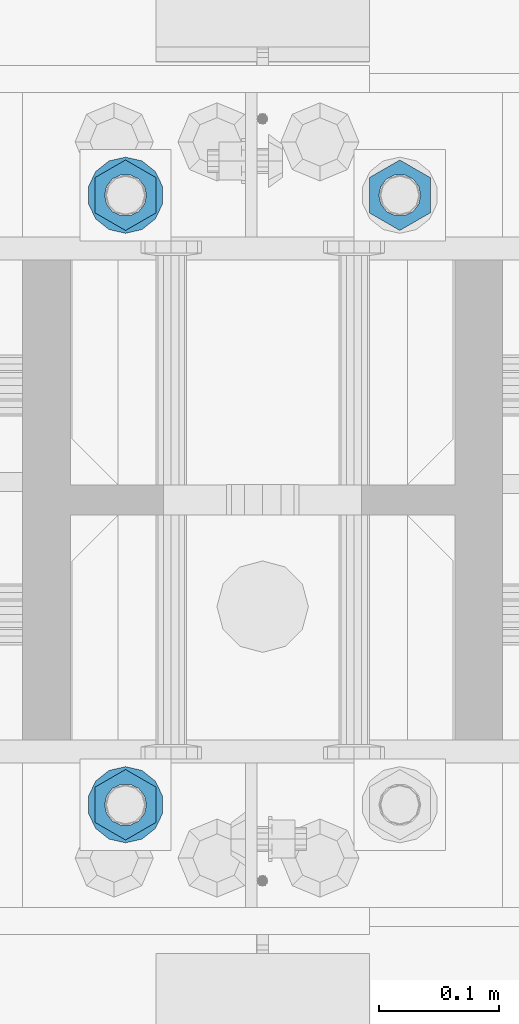
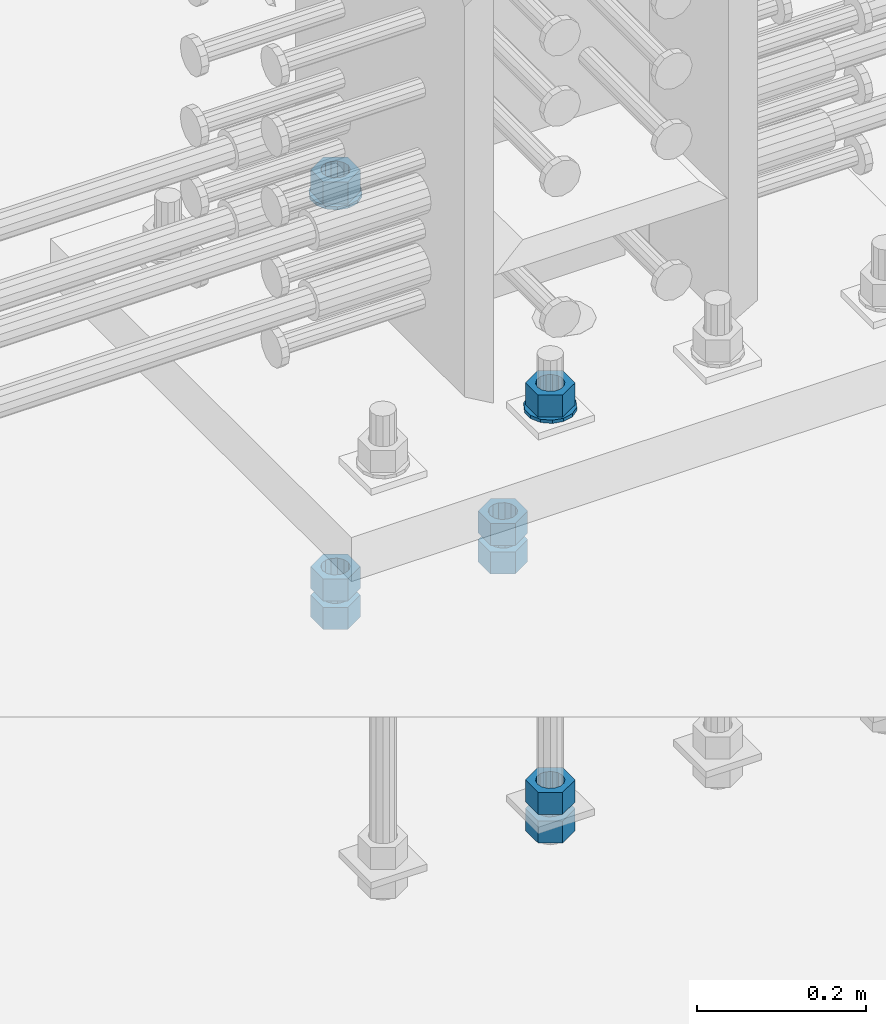
# One storey, part 1005 of 1763: 10 columns, 1 element without a shape of its own.
"""IFC2X3 building model written with IfcOpenShell, lengths in millimetres."""

import ifcopenshell
import ifcopenshell.guid

model = None  # the IFC model being written
_history = None  # IfcOwnerHistory: only IFC2X3 demands one
_inside = {}  # id of a spatial element -> (the spatial element, [elements in it])
_under = {}  # id of a project, library or spatial element -> (it, [spatial elements below it])
_declared = {}  # id of a project -> (the project, [libraries it declares])
_typed = {}  # id of a type object -> (the type object, [elements of that type])
_made_of = {}  # id of a material, layer set ... -> (it, [elements and type objects made of it])


def new_model(schema):
    """Start an empty IFC model of exactly this schema.

    Asked for "IFC4X3", IfcOpenShell would pick the latest addendum, in which some entities
    have other attributes; the version numbers below select the first issue.
    IFC2X3 requires an IfcOwnerHistory on every rooted entity: one is made here for all.
    """
    global model, _history
    if schema == "IFC4X3":
        model = ifcopenshell.file(schema_version=(4, 3, 0, 0))
    else:
        model = ifcopenshell.file(schema=schema)
    _inside.clear()
    _under.clear()
    _declared.clear()
    _typed.clear()
    _made_of.clear()
    _history = None
    if model.schema == "IFC2X3":
        org = make("IfcOrganization", Name="unknown")
        user = make(
            "IfcPersonAndOrganization",
            ThePerson=make("IfcPerson", FamilyName="unknown"),
            TheOrganization=org,
        )
        app = make(
            "IfcApplication",
            ApplicationDeveloper=org,
            Version="unknown",
            ApplicationFullName="unknown",
            ApplicationIdentifier="unknown",
        )
        _history = make(
            "IfcOwnerHistory",
            OwningUser=user,
            OwningApplication=app,
            ChangeAction="ADDED",
            CreationDate=0,
        )
    return model


def make(cls, **values):
    """One entity of the class cls with the attributes given. An attribute that is None is left unset."""
    return model.create_entity(
        cls, **{name: value for name, value in values.items() if value is not None}
    )


def rooted(cls, **values):
    """An entity with a GlobalId (a new one), such as an element, a storey or a relation."""
    return make(cls, GlobalId=ifcopenshell.guid.new(), OwnerHistory=_history, **values)


def si_unit(unit_type, name, prefix=None):
    """IfcSIUnit, for example si_unit("LENGTHUNIT", "METRE", prefix="MILLI")."""
    return make("IfcSIUnit", UnitType=unit_type, Prefix=prefix, Name=name)


def assignment(units):
    """IfcUnitAssignment: the units of a project."""
    return None if units is None else make("IfcUnitAssignment", Units=units)


def point(xyz):
    """IfcCartesianPoint."""
    return None if xyz is None else make("IfcCartesianPoint", Coordinates=xyz)


def direction(xyz):
    """IfcDirection."""
    return None if xyz is None else make("IfcDirection", DirectionRatios=xyz)


def frame(location, z_axis=None, x_axis=None):
    """IfcAxis2Placement3D, a coordinate frame: its origin and axes. An axis left out is left unset."""
    return make(
        "IfcAxis2Placement3D",
        Location=point(location),
        Axis=direction(z_axis),
        RefDirection=direction(x_axis),
    )


def origin_with_axes():
    """The frame at (0, 0, 0) with the z axis (0, 0, 1) and the x axis (1, 0, 0) written out."""
    return frame((0.0, 0.0, 0.0), z_axis=(0.0, 0.0, 1.0), x_axis=(1.0, 0.0, 0.0))


def place(relative_to, where):
    """IfcLocalPlacement: puts the frame where relative to a parent placement (None: the world)."""
    return make(
        "IfcLocalPlacement", PlacementRelTo=relative_to, RelativePlacement=where
    )


def context(
    kind, dimensions, precision=None, world=None, true_north=None, identifier=None
):
    """IfcGeometricRepresentationContext, for example the 3D "Model" context."""
    return make(
        "IfcGeometricRepresentationContext",
        ContextIdentifier=identifier,
        ContextType=kind,
        CoordinateSpaceDimension=dimensions,
        Precision=precision,
        WorldCoordinateSystem=world,
        TrueNorth=true_north,
    )


def subcontext(parent, identifier, kind, view, scale=None):
    """IfcGeometricRepresentationSubContext, for example "Body" below "Model"."""
    return make(
        "IfcGeometricRepresentationSubContext",
        ContextIdentifier=identifier,
        ContextType=kind,
        ParentContext=parent,
        TargetScale=scale,
        TargetView=view,
    )


def project(units=None, contexts=None):
    """IfcProject with its units and contexts."""
    return rooted(
        "IfcProject",
        Name="project",
        RepresentationContexts=contexts,
        UnitsInContext=assignment(units),
    )


def spatial(cls, under=None, at=None, **own):
    """A site, building, storey or space (cls), placed at a placement, below another one or the project."""
    s = rooted(cls, ObjectPlacement=at, **own)
    if under is not None:
        _under.setdefault(under.id(), (under, []))[1].append(s)
    return s


def faces_of(points, faces, orient=None, outer=None):
    """IfcFace entities. A face is a list of loops; a loop is a list of indices into points, from 0.

    orient and outer hold one flag for each loop. By default every Orientation is true, the
    first loop of a face is its IfcFaceOuterBound and the others are IfcFaceBound.
    """
    made = []
    for i, loops in enumerate(faces):
        bounds = []
        for j, loop in enumerate(loops):
            is_outer = j == 0 if outer is None else outer[i][j]
            bounds.append(
                make(
                    "IfcFaceOuterBound" if is_outer else "IfcFaceBound",
                    Bound=make("IfcPolyLoop", Polygon=[points[k] for k in loop]),
                    Orientation=True if orient is None else orient[i][j],
                )
            )
        made.append(make("IfcFace", Bounds=bounds))
    return made


def faceted_brep(points, faces, orient=None, outer=None, voids=None):
    """IfcFacetedBrep: a solid bounded by flat faces; with voids (closed shells), ...WithVoids."""
    shared = [point(p) for p in points]
    hull = make("IfcClosedShell", CfsFaces=faces_of(shared, faces, orient, outer))
    if voids is None:
        return make("IfcFacetedBrep", Outer=hull)
    return make(
        "IfcFacetedBrepWithVoids",
        Outer=hull,
        Voids=[
            make(cls, CfsFaces=faces_of(shared, fs, o, b)) for cls, fs, o, b in voids
        ],
    )


def shape(context_of_items, identifier, shape_type, items):
    """IfcShapeRepresentation: the items that make up one representation, for example the "Body"."""
    return make(
        "IfcShapeRepresentation",
        ContextOfItems=context_of_items,
        RepresentationIdentifier=identifier,
        RepresentationType=shape_type,
        Items=items,
    )


def material(Name=None, Category=None):
    """IfcMaterial."""
    return make("IfcMaterial", Name=Name, Category=Category)


def made_of(thing, what):
    """Note that an element or type object is made of a material, layer set ...; save() writes the relation."""
    if what is not None:
        _made_of.setdefault(what.id(), (what, []))[1].append(thing)
    return thing


def type_object(cls, material=None, **own):
    """A type object (cls), such as IfcWallType, which elements share."""
    return made_of(rooted(cls, **own), material)


def element(
    cls,
    number,
    at=None,
    inside=None,
    cuts=None,
    type_object=None,
    material=None,
    context=None,
    identifier="Body",
    shape_type=None,
    held_by="IfcProductDefinitionShape",
    body=None,
    shapes=None,
    **own,
):
    """One element of the class cls, such as IfcWall. Its Tag is "e" and its number.

    at: its placement. inside: the storey or other place that contains it. cuts: it is an
    opening in that element (IfcRelVoidsElement). A single representation is given by context,
    identifier, shape_type and body (its items); several are given by shapes. held_by: the class
    of the entity that holds the representations. save() writes the other relations.
    """
    e = rooted(cls, Tag="e%d" % number, ObjectPlacement=at, **own)
    if body is not None:
        shapes = [shape(context, identifier, shape_type, body)]
    if shapes is not None:
        e.Representation = make(held_by, Representations=shapes)
    if inside is not None:
        _inside.setdefault(inside.id(), (inside, []))[1].append(e)
    if cuts is not None:
        rooted(
            "IfcRelVoidsElement", RelatingBuildingElement=cuts, RelatedOpeningElement=e
        )
    if type_object is not None:
        _typed.setdefault(type_object.id(), (type_object, []))[1].append(e)
    return made_of(e, material)


def aggregate(whole, parts):
    """IfcRelAggregates: a whole, such as a stair, and the parts it consists of."""
    return rooted("IfcRelAggregates", RelatingObject=whole, RelatedObjects=parts)


def save(model, path):
    """Write the relations noted so far, then the file.

    IfcRelAggregates (storeys below a building ...), IfcRelContainedInSpatialStructure (elements
    in a storey), IfcRelDefinesByType, IfcRelAssociatesMaterial and IfcRelDeclares: one each for
    every whole, place, type object, material and project.
    """
    for whole, parts in _under.values():
        aggregate(whole, parts)
    for where, things in _inside.values():
        rooted(
            "IfcRelContainedInSpatialStructure",
            RelatedElements=things,
            RelatingStructure=where,
        )
    for kind, things in _typed.values():
        rooted("IfcRelDefinesByType", RelatedObjects=things, RelatingType=kind)
    for what, things in _made_of.values():
        rooted("IfcRelAssociatesMaterial", RelatedObjects=things, RelatingMaterial=what)
    for by, libraries in _declared.values():
        rooted("IfcRelDeclares", RelatingContext=by, RelatedDefinitions=libraries)
    model.write(path)


model = new_model("IFC2X3")

# Units and contexts
model_context = context("Model", 3, precision=1e-05, world=origin_with_axes())
body_context = subcontext(model_context, "Body", "Model", "MODEL_VIEW")
ifc_project = project(units=[si_unit("LENGTHUNIT", "METRE", prefix="MILLI"), si_unit("AREAUNIT", "SQUARE_METRE"), si_unit("VOLUMEUNIT", "CUBIC_METRE"), si_unit("MASSUNIT", "GRAM", prefix="KILO"), si_unit("TIMEUNIT", "SECOND"), si_unit("PLANEANGLEUNIT", "RADIAN"), si_unit("SOLIDANGLEUNIT", "STERADIAN"), si_unit("THERMODYNAMICTEMPERATUREUNIT", "DEGREE_CELSIUS"), si_unit("LUMINOUSINTENSITYUNIT", "LUMEN")], contexts=[model_context])

# Site, building, storey
site_placement = place(None, origin_with_axes())
site = spatial("IfcSite", under=ifc_project, at=site_placement, CompositionType="ELEMENT")
building_placement = place(site_placement, origin_with_axes())
building = spatial("IfcBuilding", under=site, at=building_placement, Name="Undefined", CompositionType="ELEMENT")
storey_placement = place(building_placement, origin_with_axes())
storey = spatial("IfcBuildingStorey", under=building, at=storey_placement, Name="Undefined", CompositionType="ELEMENT", Elevation=0.0)

# Assembly, columns
assembly_placement = place(storey_placement, origin_with_axes())
assembly = element("IfcElementAssembly", 1, at=assembly_placement, inside=storey, Name="TEMPLATE", AssemblyPlace="NOTDEFINED", PredefinedType="RIGID_FRAME")
ifc_material_1 = material(Name="STEEL/A563")
column_type_1 = type_object("IfcColumnType", Name="1-1/4_HEAVY_HEX_NUT", PredefinedType="NOTDEFINED")
column_1_placement = place(assembly_placement, frame((-34835.537273698, 711.199999999951, 3384.55), z_axis=(-1.0, 0.0, 0.0), x_axis=(0.0, 0.0, -1.0)))
column_1 = element("IfcColumn", 2, at=column_1_placement, type_object=column_type_1, material=ifc_material_1, Name="NUT", ObjectType="1-1/4_HEAVY_HEX_NUT", context=body_context, shape_type="Brep", body=[
    faceted_brep([(0.0, -29.3700008392334, 0.0), (0.0, -14.6800003051758, -25.4300003051758), (31.75, -14.6800003051758, -25.4300003051758), (31.75, -29.3700008392334, 0.0), (0.0, 14.6800003051758, -25.4300003051758), (31.75, 14.6800003051758, -25.4300003051758), (0.0, 29.3700008392334, 0.0), (31.75, 29.3700008392334, 0.0), (0.0, 14.6800003051758, 25.4300003051758), (31.75, 14.6800003051758, 25.4300003051758), (0.0, -14.6800003051758, 25.4300003051758), (31.75, -14.6800003051758, 25.4300003051758), (0.0, 0.0, 17.4599990844727), (0.0, 7.57560968776022, 15.730915608714), (31.75, 7.57560968775942, 15.7309156087145), (31.75, 0.0, 17.4599990844727), (0.0, 13.6507769681037, 10.8861313696252), (31.75, 13.6507769681048, 10.8861313696314), (0.0, 17.0222404541215, 3.88521530314756), (31.75, 17.02224045412, 3.88521530315316), (0.0, 17.0222404541215, -3.88521530314756), (31.75, 17.02224045412, -3.88521530315332), (0.0, 13.6507769681037, -10.8861313696252), (31.75, 13.6507769681048, -10.8861313696316), (0.0, 7.57560968776022, -15.730915608714), (31.75, 7.57560968775942, -15.7309156087146), (0.0, 0.0, -17.4599990844727), (31.75, 0.0, -17.4599990844727), (0.0, -7.57560968776022, -15.730915608714), (31.75, -7.57560968775942, -15.7309156087145), (0.0, -13.6507769681037, -10.8861313696252), (31.75, -13.6507769681048, -10.8861313696314), (0.0, -17.0222404541215, -3.88521530314756), (31.75, -17.02224045412, -3.88521530315316), (0.0, -17.0222404541215, 3.88521530314756), (31.75, -17.02224045412, 3.88521530315332), (0.0, -13.6507769681037, 10.8861313696252), (31.75, -13.6507769681048, 10.8861313696316), (0.0, -7.57560968776022, 15.730915608714), (31.75, -7.57560968775942, 15.7309156087146)], [[[0, 1, 2, 3]], [[1, 4, 5, 2]], [[4, 6, 7, 5]], [[6, 8, 9, 7]], [[8, 10, 11, 9]], [[10, 0, 3, 11]], [[12, 13, 14, 15]], [[13, 16, 17, 14]], [[16, 18, 19, 17]], [[18, 20, 21, 19]], [[20, 22, 23, 21]], [[22, 24, 25, 23]], [[24, 26, 27, 25]], [[26, 28, 29, 27]], [[28, 30, 31, 29]], [[30, 32, 33, 31]], [[32, 34, 35, 33]], [[34, 36, 37, 35]], [[36, 38, 39, 37]], [[38, 12, 15, 39]], [[5, 7, 9, 11, 3, 2], [17, 19, 21, 23, 25, 27, 29, 31, 33, 35, 37, 39, 15, 14]], [[10, 8, 6, 4, 1, 0], [38, 36, 34, 32, 30, 28, 26, 24, 22, 20, 18, 16, 13, 12]]]),
])
column_2_placement = place(assembly_placement, frame((-34835.537273698, 711.199999999951, 3343.275), z_axis=(-1.0, 0.0, 0.0), x_axis=(0.0, 0.0, -1.0)))
column_2 = element("IfcColumn", 3, at=column_2_placement, type_object=column_type_1, material=ifc_material_1, Name="NUT", ObjectType="1-1/4_HEAVY_HEX_NUT", context=body_context, shape_type="Brep", body=[
    faceted_brep([(0.0, -29.3700008392334, 0.0), (0.0, -14.6800003051758, -25.4300003051758), (31.75, -14.6800003051758, -25.4300003051758), (31.75, -29.3700008392334, 0.0), (0.0, 14.6800003051758, -25.4300003051758), (31.75, 14.6800003051758, -25.4300003051758), (0.0, 29.3700008392334, 0.0), (31.75, 29.3700008392334, 0.0), (0.0, 14.6800003051758, 25.4300003051758), (31.75, 14.6800003051758, 25.4300003051758), (0.0, -14.6800003051758, 25.4300003051758), (31.75, -14.6800003051758, 25.4300003051758), (0.0, 0.0, 17.4599990844727), (0.0, 7.57560968776022, 15.730915608714), (31.75, 7.57560968775942, 15.7309156087145), (31.75, 0.0, 17.4599990844727), (0.0, 13.6507769681037, 10.8861313696252), (31.75, 13.6507769681048, 10.8861313696314), (0.0, 17.0222404541215, 3.88521530314756), (31.75, 17.02224045412, 3.88521530315316), (0.0, 17.0222404541215, -3.88521530314756), (31.75, 17.02224045412, -3.88521530315332), (0.0, 13.6507769681037, -10.8861313696252), (31.75, 13.6507769681048, -10.8861313696316), (0.0, 7.57560968776022, -15.730915608714), (31.75, 7.57560968775942, -15.7309156087146), (0.0, 0.0, -17.4599990844727), (31.75, 0.0, -17.4599990844727), (0.0, -7.57560968776022, -15.730915608714), (31.75, -7.57560968775942, -15.7309156087145), (0.0, -13.6507769681037, -10.8861313696252), (31.75, -13.6507769681048, -10.8861313696314), (0.0, -17.0222404541215, -3.88521530314756), (31.75, -17.02224045412, -3.88521530315316), (0.0, -17.0222404541215, 3.88521530314756), (31.75, -17.02224045412, 3.88521530315332), (0.0, -13.6507769681037, 10.8861313696252), (31.75, -13.6507769681048, 10.8861313696316), (0.0, -7.57560968776022, 15.730915608714), (31.75, -7.57560968775942, 15.7309156087146)], [[[0, 1, 2, 3]], [[1, 4, 5, 2]], [[4, 6, 7, 5]], [[6, 8, 9, 7]], [[8, 10, 11, 9]], [[10, 0, 3, 11]], [[12, 13, 14, 15]], [[13, 16, 17, 14]], [[16, 18, 19, 17]], [[18, 20, 21, 19]], [[20, 22, 23, 21]], [[22, 24, 25, 23]], [[24, 26, 27, 25]], [[26, 28, 29, 27]], [[28, 30, 31, 29]], [[30, 32, 33, 31]], [[32, 34, 35, 33]], [[34, 36, 37, 35]], [[36, 38, 39, 37]], [[38, 12, 15, 39]], [[5, 7, 9, 11, 3, 2], [17, 19, 21, 23, 25, 27, 29, 31, 33, 35, 37, 39, 15, 14]], [[10, 8, 6, 4, 1, 0], [38, 36, 34, 32, 30, 28, 26, 24, 22, 20, 18, 16, 13, 12]]]),
])
column_3_placement = place(assembly_placement, frame((-35064.137273698, 203.199999999951, 3957.6375), z_axis=(1.0, 0.0, 0.0), x_axis=(0.0, 0.0, -1.0)))
column_3 = element("IfcColumn", 4, at=column_3_placement, type_object=column_type_1, material=ifc_material_1, Name="NUT", ObjectType="1-1/4_HEAVY_HEX_NUT", context=body_context, shape_type="Brep", body=[
    faceted_brep([(0.0, -29.3700008392334, 0.0), (0.0, -14.6800003051758, -25.4300003051758), (31.75, -14.6800003051758, -25.4300003051758), (31.75, -29.3700008392334, 0.0), (0.0, 14.6800003051758, -25.4300003051758), (31.75, 14.6800003051758, -25.4300003051758), (0.0, 29.3700008392334, 0.0), (31.75, 29.3700008392334, 0.0), (0.0, 14.6800003051758, 25.4300003051758), (31.75, 14.6800003051758, 25.4300003051758), (0.0, -14.6800003051758, 25.4300003051758), (31.75, -14.6800003051758, 25.4300003051758), (0.0, 0.0, 17.4599990844727), (0.0, 7.57560968776022, 15.730915608714), (31.75, 7.57560968775942, 15.7309156087145), (31.75, 0.0, 17.4599990844727), (0.0, 13.6507769681037, 10.8861313696252), (31.75, 13.6507769681048, 10.8861313696314), (0.0, 17.0222404541215, 3.88521530314756), (31.75, 17.02224045412, 3.88521530315316), (0.0, 17.0222404541215, -3.88521530314756), (31.75, 17.02224045412, -3.88521530315332), (0.0, 13.6507769681037, -10.8861313696252), (31.75, 13.6507769681048, -10.8861313696316), (0.0, 7.57560968776022, -15.730915608714), (31.75, 7.57560968775942, -15.7309156087146), (0.0, 0.0, -17.4599990844727), (31.75, 0.0, -17.4599990844727), (0.0, -7.57560968776022, -15.730915608714), (31.75, -7.57560968775942, -15.7309156087145), (0.0, -13.6507769681037, -10.8861313696252), (31.75, -13.6507769681048, -10.8861313696314), (0.0, -17.0222404541215, -3.88521530314756), (31.75, -17.02224045412, -3.88521530315316), (0.0, -17.0222404541215, 3.88521530314756), (31.75, -17.02224045412, 3.88521530315332), (0.0, -13.6507769681037, 10.8861313696252), (31.75, -13.6507769681048, 10.8861313696316), (0.0, -7.57560968776022, 15.730915608714), (31.75, -7.57560968775942, 15.7309156087146)], [[[0, 1, 2, 3]], [[1, 4, 5, 2]], [[4, 6, 7, 5]], [[6, 8, 9, 7]], [[8, 10, 11, 9]], [[10, 0, 3, 11]], [[12, 13, 14, 15]], [[13, 16, 17, 14]], [[16, 18, 19, 17]], [[18, 20, 21, 19]], [[20, 22, 23, 21]], [[22, 24, 25, 23]], [[24, 26, 27, 25]], [[26, 28, 29, 27]], [[28, 30, 31, 29]], [[30, 32, 33, 31]], [[32, 34, 35, 33]], [[34, 36, 37, 35]], [[36, 38, 39, 37]], [[38, 12, 15, 39]], [[5, 7, 9, 11, 3, 2], [17, 19, 21, 23, 25, 27, 29, 31, 33, 35, 37, 39, 15, 14]], [[10, 8, 6, 4, 1, 0], [38, 36, 34, 32, 30, 28, 26, 24, 22, 20, 18, 16, 13, 12]]]),
])
column_4_placement = place(assembly_placement, frame((-35064.137273698, 203.199999999951, 3384.55), z_axis=(1.0, 0.0, 0.0), x_axis=(0.0, 0.0, -1.0)))
column_4 = element("IfcColumn", 5, at=column_4_placement, type_object=column_type_1, material=ifc_material_1, Name="NUT", ObjectType="1-1/4_HEAVY_HEX_NUT", context=body_context, shape_type="Brep", body=[
    faceted_brep([(0.0, -29.3700008392334, 0.0), (0.0, -14.6800003051758, -25.4300003051758), (31.75, -14.6800003051758, -25.4300003051758), (31.75, -29.3700008392334, 0.0), (0.0, 14.6800003051758, -25.4300003051758), (31.75, 14.6800003051758, -25.4300003051758), (0.0, 29.3700008392334, 0.0), (31.75, 29.3700008392334, 0.0), (0.0, 14.6800003051758, 25.4300003051758), (31.75, 14.6800003051758, 25.4300003051758), (0.0, -14.6800003051758, 25.4300003051758), (31.75, -14.6800003051758, 25.4300003051758), (0.0, 0.0, 17.4599990844727), (0.0, 7.57560968776022, 15.730915608714), (31.75, 7.57560968775942, 15.7309156087145), (31.75, 0.0, 17.4599990844727), (0.0, 13.6507769681037, 10.8861313696252), (31.75, 13.6507769681048, 10.8861313696314), (0.0, 17.0222404541215, 3.88521530314756), (31.75, 17.02224045412, 3.88521530315316), (0.0, 17.0222404541215, -3.88521530314756), (31.75, 17.02224045412, -3.88521530315332), (0.0, 13.6507769681037, -10.8861313696252), (31.75, 13.6507769681048, -10.8861313696316), (0.0, 7.57560968776022, -15.730915608714), (31.75, 7.57560968775942, -15.7309156087146), (0.0, 0.0, -17.4599990844727), (31.75, 0.0, -17.4599990844727), (0.0, -7.57560968776022, -15.730915608714), (31.75, -7.57560968775942, -15.7309156087145), (0.0, -13.6507769681037, -10.8861313696252), (31.75, -13.6507769681048, -10.8861313696314), (0.0, -17.0222404541215, -3.88521530314756), (31.75, -17.02224045412, -3.88521530315316), (0.0, -17.0222404541215, 3.88521530314756), (31.75, -17.02224045412, 3.88521530315332), (0.0, -13.6507769681037, 10.8861313696252), (31.75, -13.6507769681048, 10.8861313696316), (0.0, -7.57560968776022, 15.730915608714), (31.75, -7.57560968775942, 15.7309156087146)], [[[0, 1, 2, 3]], [[1, 4, 5, 2]], [[4, 6, 7, 5]], [[6, 8, 9, 7]], [[8, 10, 11, 9]], [[10, 0, 3, 11]], [[12, 13, 14, 15]], [[13, 16, 17, 14]], [[16, 18, 19, 17]], [[18, 20, 21, 19]], [[20, 22, 23, 21]], [[22, 24, 25, 23]], [[24, 26, 27, 25]], [[26, 28, 29, 27]], [[28, 30, 31, 29]], [[30, 32, 33, 31]], [[32, 34, 35, 33]], [[34, 36, 37, 35]], [[36, 38, 39, 37]], [[38, 12, 15, 39]], [[5, 7, 9, 11, 3, 2], [17, 19, 21, 23, 25, 27, 29, 31, 33, 35, 37, 39, 15, 14]], [[10, 8, 6, 4, 1, 0], [38, 36, 34, 32, 30, 28, 26, 24, 22, 20, 18, 16, 13, 12]]]),
])
column_5_placement = place(assembly_placement, frame((-35064.137273698, 203.199999999951, 3343.275), z_axis=(1.0, 0.0, 0.0), x_axis=(0.0, 0.0, -1.0)))
column_5 = element("IfcColumn", 6, at=column_5_placement, type_object=column_type_1, material=ifc_material_1, Name="NUT", ObjectType="1-1/4_HEAVY_HEX_NUT", context=body_context, shape_type="Brep", body=[
    faceted_brep([(0.0, -29.3700008392334, 0.0), (0.0, -14.6800003051758, -25.4300003051758), (31.75, -14.6800003051758, -25.4300003051758), (31.75, -29.3700008392334, 0.0), (0.0, 14.6800003051758, -25.4300003051758), (31.75, 14.6800003051758, -25.4300003051758), (0.0, 29.3700008392334, 0.0), (31.75, 29.3700008392334, 0.0), (0.0, 14.6800003051758, 25.4300003051758), (31.75, 14.6800003051758, 25.4300003051758), (0.0, -14.6800003051758, 25.4300003051758), (31.75, -14.6800003051758, 25.4300003051758), (0.0, 0.0, 17.4599990844727), (0.0, 7.57560968776022, 15.730915608714), (31.75, 7.57560968775942, 15.7309156087145), (31.75, 0.0, 17.4599990844727), (0.0, 13.6507769681037, 10.8861313696252), (31.75, 13.6507769681048, 10.8861313696314), (0.0, 17.0222404541215, 3.88521530314756), (31.75, 17.02224045412, 3.88521530315316), (0.0, 17.0222404541215, -3.88521530314756), (31.75, 17.02224045412, -3.88521530315332), (0.0, 13.6507769681037, -10.8861313696252), (31.75, 13.6507769681048, -10.8861313696316), (0.0, 7.57560968776022, -15.730915608714), (31.75, 7.57560968775942, -15.7309156087146), (0.0, 0.0, -17.4599990844727), (31.75, 0.0, -17.4599990844727), (0.0, -7.57560968776022, -15.730915608714), (31.75, -7.57560968775942, -15.7309156087145), (0.0, -13.6507769681037, -10.8861313696252), (31.75, -13.6507769681048, -10.8861313696314), (0.0, -17.0222404541215, -3.88521530314756), (31.75, -17.02224045412, -3.88521530315316), (0.0, -17.0222404541215, 3.88521530314756), (31.75, -17.02224045412, 3.88521530315332), (0.0, -13.6507769681037, 10.8861313696252), (31.75, -13.6507769681048, 10.8861313696316), (0.0, -7.57560968776022, 15.730915608714), (31.75, -7.57560968775942, 15.7309156087146)], [[[0, 1, 2, 3]], [[1, 4, 5, 2]], [[4, 6, 7, 5]], [[6, 8, 9, 7]], [[8, 10, 11, 9]], [[10, 0, 3, 11]], [[12, 13, 14, 15]], [[13, 16, 17, 14]], [[16, 18, 19, 17]], [[18, 20, 21, 19]], [[20, 22, 23, 21]], [[22, 24, 25, 23]], [[24, 26, 27, 25]], [[26, 28, 29, 27]], [[28, 30, 31, 29]], [[30, 32, 33, 31]], [[32, 34, 35, 33]], [[34, 36, 37, 35]], [[36, 38, 39, 37]], [[38, 12, 15, 39]], [[5, 7, 9, 11, 3, 2], [17, 19, 21, 23, 25, 27, 29, 31, 33, 35, 37, 39, 15, 14]], [[10, 8, 6, 4, 1, 0], [38, 36, 34, 32, 30, 28, 26, 24, 22, 20, 18, 16, 13, 12]]]),
])
column_6_placement = place(assembly_placement, frame((-35064.137273698, 711.199999999951, 3957.6375), z_axis=(-1.0, 0.0, 0.0), x_axis=(0.0, 0.0, -1.0)))
column_6 = element("IfcColumn", 7, at=column_6_placement, type_object=column_type_1, material=ifc_material_1, Name="NUT", ObjectType="1-1/4_HEAVY_HEX_NUT", context=body_context, shape_type="Brep", body=[
    faceted_brep([(0.0, -29.3700008392334, 0.0), (0.0, -14.6800003051758, -25.4300003051758), (31.75, -14.6800003051758, -25.4300003051758), (31.75, -29.3700008392334, 0.0), (0.0, 14.6800003051758, -25.4300003051758), (31.75, 14.6800003051758, -25.4300003051758), (0.0, 29.3700008392334, 0.0), (31.75, 29.3700008392334, 0.0), (0.0, 14.6800003051758, 25.4300003051758), (31.75, 14.6800003051758, 25.4300003051758), (0.0, -14.6800003051758, 25.4300003051758), (31.75, -14.6800003051758, 25.4300003051758), (0.0, 0.0, 17.4599990844727), (0.0, 7.57560968776022, 15.730915608714), (31.75, 7.57560968775942, 15.7309156087145), (31.75, 0.0, 17.4599990844727), (0.0, 13.6507769681037, 10.8861313696252), (31.75, 13.6507769681048, 10.8861313696314), (0.0, 17.0222404541215, 3.88521530314756), (31.75, 17.02224045412, 3.88521530315316), (0.0, 17.0222404541215, -3.88521530314756), (31.75, 17.02224045412, -3.88521530315332), (0.0, 13.6507769681037, -10.8861313696252), (31.75, 13.6507769681048, -10.8861313696316), (0.0, 7.57560968776022, -15.730915608714), (31.75, 7.57560968775942, -15.7309156087146), (0.0, 0.0, -17.4599990844727), (31.75, 0.0, -17.4599990844727), (0.0, -7.57560968776022, -15.730915608714), (31.75, -7.57560968775942, -15.7309156087145), (0.0, -13.6507769681037, -10.8861313696252), (31.75, -13.6507769681048, -10.8861313696314), (0.0, -17.0222404541215, -3.88521530314756), (31.75, -17.02224045412, -3.88521530315316), (0.0, -17.0222404541215, 3.88521530314756), (31.75, -17.02224045412, 3.88521530315332), (0.0, -13.6507769681037, 10.8861313696252), (31.75, -13.6507769681048, 10.8861313696316), (0.0, -7.57560968776022, 15.730915608714), (31.75, -7.57560968775942, 15.7309156087146)], [[[0, 1, 2, 3]], [[1, 4, 5, 2]], [[4, 6, 7, 5]], [[6, 8, 9, 7]], [[8, 10, 11, 9]], [[10, 0, 3, 11]], [[12, 13, 14, 15]], [[13, 16, 17, 14]], [[16, 18, 19, 17]], [[18, 20, 21, 19]], [[20, 22, 23, 21]], [[22, 24, 25, 23]], [[24, 26, 27, 25]], [[26, 28, 29, 27]], [[28, 30, 31, 29]], [[30, 32, 33, 31]], [[32, 34, 35, 33]], [[34, 36, 37, 35]], [[36, 38, 39, 37]], [[38, 12, 15, 39]], [[5, 7, 9, 11, 3, 2], [17, 19, 21, 23, 25, 27, 29, 31, 33, 35, 37, 39, 15, 14]], [[10, 8, 6, 4, 1, 0], [38, 36, 34, 32, 30, 28, 26, 24, 22, 20, 18, 16, 13, 12]]]),
])
column_7_placement = place(assembly_placement, frame((-35064.137273698, 711.199999999951, 3384.55), z_axis=(-1.0, 0.0, 0.0), x_axis=(0.0, 0.0, -1.0)))
column_7 = element("IfcColumn", 8, at=column_7_placement, type_object=column_type_1, material=ifc_material_1, Name="NUT", ObjectType="1-1/4_HEAVY_HEX_NUT", context=body_context, shape_type="Brep", body=[
    faceted_brep([(0.0, -29.3700008392334, 0.0), (0.0, -14.6800003051758, -25.4300003051758), (31.75, -14.6800003051758, -25.4300003051758), (31.75, -29.3700008392334, 0.0), (0.0, 14.6800003051758, -25.4300003051758), (31.75, 14.6800003051758, -25.4300003051758), (0.0, 29.3700008392334, 0.0), (31.75, 29.3700008392334, 0.0), (0.0, 14.6800003051758, 25.4300003051758), (31.75, 14.6800003051758, 25.4300003051758), (0.0, -14.6800003051758, 25.4300003051758), (31.75, -14.6800003051758, 25.4300003051758), (0.0, 0.0, 17.4599990844727), (0.0, 7.57560968776022, 15.730915608714), (31.75, 7.57560968775942, 15.7309156087145), (31.75, 0.0, 17.4599990844727), (0.0, 13.6507769681037, 10.8861313696252), (31.75, 13.6507769681048, 10.8861313696314), (0.0, 17.0222404541215, 3.88521530314756), (31.75, 17.02224045412, 3.88521530315316), (0.0, 17.0222404541215, -3.88521530314756), (31.75, 17.02224045412, -3.88521530315332), (0.0, 13.6507769681037, -10.8861313696252), (31.75, 13.6507769681048, -10.8861313696316), (0.0, 7.57560968776022, -15.730915608714), (31.75, 7.57560968775942, -15.7309156087146), (0.0, 0.0, -17.4599990844727), (31.75, 0.0, -17.4599990844727), (0.0, -7.57560968776022, -15.730915608714), (31.75, -7.57560968775942, -15.7309156087145), (0.0, -13.6507769681037, -10.8861313696252), (31.75, -13.6507769681048, -10.8861313696314), (0.0, -17.0222404541215, -3.88521530314756), (31.75, -17.02224045412, -3.88521530315316), (0.0, -17.0222404541215, 3.88521530314756), (31.75, -17.02224045412, 3.88521530315332), (0.0, -13.6507769681037, 10.8861313696252), (31.75, -13.6507769681048, 10.8861313696316), (0.0, -7.57560968776022, 15.730915608714), (31.75, -7.57560968775942, 15.7309156087146)], [[[0, 1, 2, 3]], [[1, 4, 5, 2]], [[4, 6, 7, 5]], [[6, 8, 9, 7]], [[8, 10, 11, 9]], [[10, 0, 3, 11]], [[12, 13, 14, 15]], [[13, 16, 17, 14]], [[16, 18, 19, 17]], [[18, 20, 21, 19]], [[20, 22, 23, 21]], [[22, 24, 25, 23]], [[24, 26, 27, 25]], [[26, 28, 29, 27]], [[28, 30, 31, 29]], [[30, 32, 33, 31]], [[32, 34, 35, 33]], [[34, 36, 37, 35]], [[36, 38, 39, 37]], [[38, 12, 15, 39]], [[5, 7, 9, 11, 3, 2], [17, 19, 21, 23, 25, 27, 29, 31, 33, 35, 37, 39, 15, 14]], [[10, 8, 6, 4, 1, 0], [38, 36, 34, 32, 30, 28, 26, 24, 22, 20, 18, 16, 13, 12]]]),
])
column_8_placement = place(assembly_placement, frame((-35064.137273698, 711.199999999951, 3343.275), z_axis=(-1.0, 0.0, 0.0), x_axis=(0.0, 0.0, -1.0)))
column_8 = element("IfcColumn", 9, at=column_8_placement, type_object=column_type_1, material=ifc_material_1, Name="NUT", ObjectType="1-1/4_HEAVY_HEX_NUT", context=body_context, shape_type="Brep", body=[
    faceted_brep([(0.0, -29.3700008392334, 0.0), (0.0, -14.6800003051758, -25.4300003051758), (31.75, -14.6800003051758, -25.4300003051758), (31.75, -29.3700008392334, 0.0), (0.0, 14.6800003051758, -25.4300003051758), (31.75, 14.6800003051758, -25.4300003051758), (0.0, 29.3700008392334, 0.0), (31.75, 29.3700008392334, 0.0), (0.0, 14.6800003051758, 25.4300003051758), (31.75, 14.6800003051758, 25.4300003051758), (0.0, -14.6800003051758, 25.4300003051758), (31.75, -14.6800003051758, 25.4300003051758), (0.0, 0.0, 17.4599990844727), (0.0, 7.57560968776022, 15.730915608714), (31.75, 7.57560968775942, 15.7309156087145), (31.75, 0.0, 17.4599990844727), (0.0, 13.6507769681037, 10.8861313696252), (31.75, 13.6507769681048, 10.8861313696314), (0.0, 17.0222404541215, 3.88521530314756), (31.75, 17.02224045412, 3.88521530315316), (0.0, 17.0222404541215, -3.88521530314756), (31.75, 17.02224045412, -3.88521530315332), (0.0, 13.6507769681037, -10.8861313696252), (31.75, 13.6507769681048, -10.8861313696316), (0.0, 7.57560968776022, -15.730915608714), (31.75, 7.57560968775942, -15.7309156087146), (0.0, 0.0, -17.4599990844727), (31.75, 0.0, -17.4599990844727), (0.0, -7.57560968776022, -15.730915608714), (31.75, -7.57560968775942, -15.7309156087145), (0.0, -13.6507769681037, -10.8861313696252), (31.75, -13.6507769681048, -10.8861313696314), (0.0, -17.0222404541215, -3.88521530314756), (31.75, -17.02224045412, -3.88521530315316), (0.0, -17.0222404541215, 3.88521530314756), (31.75, -17.02224045412, 3.88521530315332), (0.0, -13.6507769681037, 10.8861313696252), (31.75, -13.6507769681048, 10.8861313696316), (0.0, -7.57560968776022, 15.730915608714), (31.75, -7.57560968775942, 15.7309156087146)], [[[0, 1, 2, 3]], [[1, 4, 5, 2]], [[4, 6, 7, 5]], [[6, 8, 9, 7]], [[8, 10, 11, 9]], [[10, 0, 3, 11]], [[12, 13, 14, 15]], [[13, 16, 17, 14]], [[16, 18, 19, 17]], [[18, 20, 21, 19]], [[20, 22, 23, 21]], [[22, 24, 25, 23]], [[24, 26, 27, 25]], [[26, 28, 29, 27]], [[28, 30, 31, 29]], [[30, 32, 33, 31]], [[32, 34, 35, 33]], [[34, 36, 37, 35]], [[36, 38, 39, 37]], [[38, 12, 15, 39]], [[5, 7, 9, 11, 3, 2], [17, 19, 21, 23, 25, 27, 29, 31, 33, 35, 37, 39, 15, 14]], [[10, 8, 6, 4, 1, 0], [38, 36, 34, 32, 30, 28, 26, 24, 22, 20, 18, 16, 13, 12]]]),
])
ifc_material_2 = material(Name="STEEL/F436")
column_type_2 = type_object("IfcColumnType", Name="1-1/4_WASHER", PredefinedType="NOTDEFINED")
column_9_placement = place(assembly_placement, frame((-35064.137273698, 203.199999999951, 3925.8875), z_axis=(1.0, 0.0, 0.0), x_axis=(0.0, 0.0, -1.0)))
column_9 = element("IfcColumn", 10, at=column_9_placement, type_object=column_type_2, material=ifc_material_2, Name="WASHER", ObjectType="1-1/4_WASHER", context=body_context, shape_type="Brep", body=[
    faceted_brep([(-4.54747350886464e-13, -31.7499999999964, 0.0), (0.0, -28.6057615559002, -13.7758087169827), (4.76249999999982, -28.6057615559002, -13.7758087169827), (4.76249999999982, -31.75, 0.0), (0.0, -19.795801209013, -24.8231495683602), (4.76249999999982, -19.795801209013, -24.8231495683602), (0.0, -7.06503965311276, -30.9539612117732), (4.76249999999982, -7.06503965311276, -30.9539612117732), (0.0, 7.06503965311276, -30.9539612117732), (4.76249999999982, 7.06503965311276, -30.9539612117732), (0.0, 19.7958012090166, -24.8231495683602), (4.76249999999982, 19.7958012090166, -24.8231495683602), (0.0, 28.6057615559039, -13.7758087169827), (4.76249999999982, 28.6057615559039, -13.7758087169827), (-5.91171556152403e-12, 31.7499999999891, 0.0), (4.76249999999982, 31.75, 0.0), (0.0, 28.6057615559002, 13.7758087169827), (4.76249999999982, 28.6057615559002, 13.7758087169827), (0.0, 19.795801209013, 24.8231495683602), (4.76249999999982, 19.795801209013, 24.8231495683602), (0.0, 7.06503965311276, 30.9539612117731), (4.76249999999982, 7.06503965311276, 30.9539612117731), (0.0, -7.06503965311276, 30.9539612117731), (4.76249999999982, -7.06503965311276, 30.9539612117731), (0.0, -19.7958012090166, 24.8231495683602), (4.76249999999982, -19.7958012090166, 24.8231495683602), (0.0, -28.6057615559039, 13.7758087169827), (4.76249999999982, -28.6057615559039, 13.7758087169827), (0.0, 0.0, 17.4599990844727), (0.0, 7.57560968776022, 15.730915608714), (4.76249999999982, 7.57560968775942, 15.7309156087145), (4.76249999999982, 0.0, 17.4599990844727), (0.0, 13.6507769681037, 10.8861313696252), (4.76249999999982, 13.6507769681048, 10.8861313696314), (0.0, 17.0222404541215, 3.88521530314756), (4.76249999999982, 17.02224045412, 3.88521530315316), (0.0, 17.0222404541215, -3.88521530314756), (4.76249999999982, 17.02224045412, -3.88521530315332), (0.0, 13.6507769681037, -10.8861313696252), (4.76249999999982, 13.6507769681048, -10.8861313696316), (0.0, 7.57560968776022, -15.730915608714), (4.76249999999982, 7.57560968775942, -15.7309156087146), (0.0, 0.0, -17.4599990844727), (4.76249999999982, 0.0, -17.4599990844727), (0.0, -7.57560968776022, -15.730915608714), (4.76249999999982, -7.57560968775942, -15.7309156087145), (0.0, -13.6507769681037, -10.8861313696252), (4.76249999999982, -13.6507769681048, -10.8861313696314), (0.0, -17.0222404541215, -3.88521530314756), (4.76249999999982, -17.02224045412, -3.88521530315316), (0.0, -17.0222404541215, 3.88521530314756), (4.76249999999982, -17.02224045412, 3.88521530315332), (0.0, -13.6507769681037, 10.8861313696252), (4.76249999999982, -13.6507769681048, 10.8861313696316), (0.0, -7.57560968776022, 15.730915608714), (4.76249999999982, -7.57560968775942, 15.7309156087146)], [[[0, 1, 2, 3]], [[1, 4, 5, 2]], [[4, 6, 7, 5]], [[6, 8, 9, 7]], [[8, 10, 11, 9]], [[10, 12, 13, 11]], [[12, 14, 15, 13]], [[14, 16, 17, 15]], [[16, 18, 19, 17]], [[18, 20, 21, 19]], [[20, 22, 23, 21]], [[22, 24, 25, 23]], [[24, 26, 27, 25]], [[26, 0, 3, 27]], [[28, 29, 30, 31]], [[29, 32, 33, 30]], [[32, 34, 35, 33]], [[34, 36, 37, 35]], [[36, 38, 39, 37]], [[38, 40, 41, 39]], [[40, 42, 43, 41]], [[42, 44, 45, 43]], [[44, 46, 47, 45]], [[46, 48, 49, 47]], [[48, 50, 51, 49]], [[50, 52, 53, 51]], [[52, 54, 55, 53]], [[54, 28, 31, 55]], [[5, 7, 9, 11, 13, 15, 17, 19, 21, 23, 25, 27, 3, 2], [33, 35, 37, 39, 41, 43, 45, 47, 49, 51, 53, 55, 31, 30]], [[26, 24, 22, 20, 18, 16, 14, 12, 10, 8, 6, 4, 1, 0], [54, 52, 50, 48, 46, 44, 42, 40, 38, 36, 34, 32, 29, 28]]]),
])
column_10_placement = place(assembly_placement, frame((-35064.137273698, 711.199999999951, 3925.8875), z_axis=(-1.0, 0.0, 0.0), x_axis=(0.0, 0.0, -1.0)))
column_10 = element("IfcColumn", 11, at=column_10_placement, type_object=column_type_2, material=ifc_material_2, Name="WASHER", ObjectType="1-1/4_WASHER", context=body_context, shape_type="Brep", body=[
    faceted_brep([(-4.54747350886464e-13, -31.7499999999964, 0.0), (0.0, -28.6057615559002, -13.7758087169827), (4.76249999999982, -28.6057615559002, -13.7758087169827), (4.76249999999982, -31.75, 0.0), (0.0, -19.795801209013, -24.8231495683602), (4.76249999999982, -19.795801209013, -24.8231495683602), (0.0, -7.06503965311276, -30.9539612117732), (4.76249999999982, -7.06503965311276, -30.9539612117732), (0.0, 7.06503965311276, -30.9539612117732), (4.76249999999982, 7.06503965311276, -30.9539612117732), (0.0, 19.7958012090166, -24.8231495683602), (4.76249999999982, 19.7958012090166, -24.8231495683602), (0.0, 28.6057615559039, -13.7758087169827), (4.76249999999982, 28.6057615559039, -13.7758087169827), (-5.91171556152403e-12, 31.7499999999891, 0.0), (4.76249999999982, 31.75, 0.0), (0.0, 28.6057615559002, 13.7758087169827), (4.76249999999982, 28.6057615559002, 13.7758087169827), (0.0, 19.795801209013, 24.8231495683602), (4.76249999999982, 19.795801209013, 24.8231495683602), (0.0, 7.06503965311276, 30.9539612117731), (4.76249999999982, 7.06503965311276, 30.9539612117731), (0.0, -7.06503965311276, 30.9539612117731), (4.76249999999982, -7.06503965311276, 30.9539612117731), (0.0, -19.7958012090166, 24.8231495683602), (4.76249999999982, -19.7958012090166, 24.8231495683602), (0.0, -28.6057615559039, 13.7758087169827), (4.76249999999982, -28.6057615559039, 13.7758087169827), (0.0, 0.0, 17.4599990844727), (0.0, 7.57560968776022, 15.730915608714), (4.76249999999982, 7.57560968775942, 15.7309156087145), (4.76249999999982, 0.0, 17.4599990844727), (0.0, 13.6507769681037, 10.8861313696252), (4.76249999999982, 13.6507769681048, 10.8861313696314), (0.0, 17.0222404541215, 3.88521530314756), (4.76249999999982, 17.02224045412, 3.88521530315316), (0.0, 17.0222404541215, -3.88521530314756), (4.76249999999982, 17.02224045412, -3.88521530315332), (0.0, 13.6507769681037, -10.8861313696252), (4.76249999999982, 13.6507769681048, -10.8861313696316), (0.0, 7.57560968776022, -15.730915608714), (4.76249999999982, 7.57560968775942, -15.7309156087146), (0.0, 0.0, -17.4599990844727), (4.76249999999982, 0.0, -17.4599990844727), (0.0, -7.57560968776022, -15.730915608714), (4.76249999999982, -7.57560968775942, -15.7309156087145), (0.0, -13.6507769681037, -10.8861313696252), (4.76249999999982, -13.6507769681048, -10.8861313696314), (0.0, -17.0222404541215, -3.88521530314756), (4.76249999999982, -17.02224045412, -3.88521530315316), (0.0, -17.0222404541215, 3.88521530314756), (4.76249999999982, -17.02224045412, 3.88521530315332), (0.0, -13.6507769681037, 10.8861313696252), (4.76249999999982, -13.6507769681048, 10.8861313696316), (0.0, -7.57560968776022, 15.730915608714), (4.76249999999982, -7.57560968775942, 15.7309156087146)], [[[0, 1, 2, 3]], [[1, 4, 5, 2]], [[4, 6, 7, 5]], [[6, 8, 9, 7]], [[8, 10, 11, 9]], [[10, 12, 13, 11]], [[12, 14, 15, 13]], [[14, 16, 17, 15]], [[16, 18, 19, 17]], [[18, 20, 21, 19]], [[20, 22, 23, 21]], [[22, 24, 25, 23]], [[24, 26, 27, 25]], [[26, 0, 3, 27]], [[28, 29, 30, 31]], [[29, 32, 33, 30]], [[32, 34, 35, 33]], [[34, 36, 37, 35]], [[36, 38, 39, 37]], [[38, 40, 41, 39]], [[40, 42, 43, 41]], [[42, 44, 45, 43]], [[44, 46, 47, 45]], [[46, 48, 49, 47]], [[48, 50, 51, 49]], [[50, 52, 53, 51]], [[52, 54, 55, 53]], [[54, 28, 31, 55]], [[5, 7, 9, 11, 13, 15, 17, 19, 21, 23, 25, 27, 3, 2], [33, 35, 37, 39, 41, 43, 45, 47, 49, 51, 53, 55, 31, 30]], [[26, 24, 22, 20, 18, 16, 14, 12, 10, 8, 6, 4, 1, 0], [54, 52, 50, 48, 46, 44, 42, 40, 38, 36, 34, 32, 29, 28]]]),
])
aggregate(assembly, [column_1, column_2, column_3, column_9, column_4, column_5, column_6, column_10, column_7, column_8])

save(model, "model.ifc")
